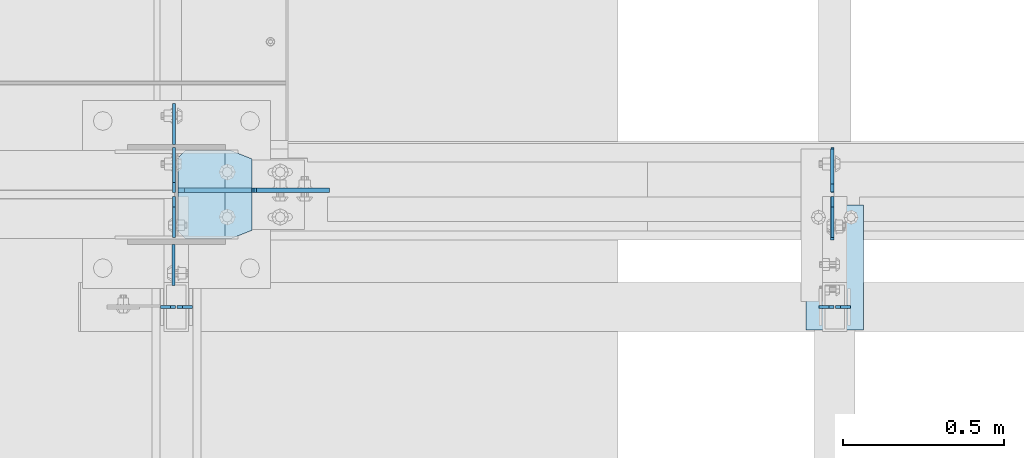
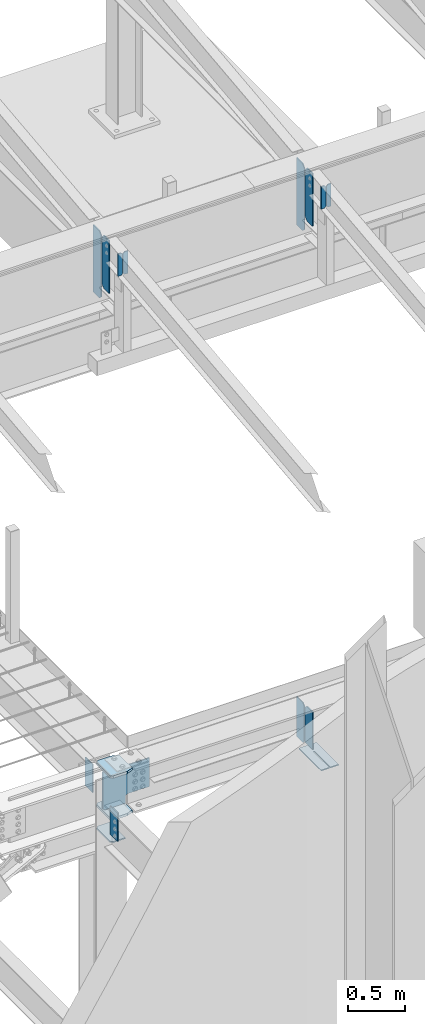
# One storey, part 988 of 1179: 17 plates, 6 elements without a shape of their own.
"""IFC2X3 building model written with IfcOpenShell, lengths in millimetres."""

from ifc_helpers import new_model, si_unit, frame, origin_with_axes, place, context, subcontext, project, spatial, faceted_brep, material, type_object, element, aggregate, save


model = new_model("IFC2X3")

# Units and contexts
model_context = context("Model", 3, precision=1e-05, world=origin_with_axes())
body_context = subcontext(model_context, "Body", "Model", "MODEL_VIEW")
ifc_project = project(units=[si_unit("LENGTHUNIT", "METRE", prefix="MILLI"), si_unit("AREAUNIT", "SQUARE_METRE"), si_unit("VOLUMEUNIT", "CUBIC_METRE"), si_unit("MASSUNIT", "GRAM", prefix="KILO"), si_unit("TIMEUNIT", "SECOND"), si_unit("PLANEANGLEUNIT", "RADIAN"), si_unit("SOLIDANGLEUNIT", "STERADIAN"), si_unit("THERMODYNAMICTEMPERATUREUNIT", "DEGREE_CELSIUS"), si_unit("LUMINOUSINTENSITYUNIT", "LUMEN")], contexts=[model_context])

# Site, building, storey
site_placement = place(None, origin_with_axes())
site = spatial("IfcSite", under=ifc_project, at=site_placement, CompositionType="ELEMENT")
building_placement = place(site_placement, origin_with_axes())
building = spatial("IfcBuilding", under=site, at=building_placement, Name="Undefined", CompositionType="ELEMENT")
storey_placement = place(building_placement, origin_with_axes())
storey = spatial("IfcBuildingStorey", under=building, at=storey_placement, Name="Undefined", CompositionType="ELEMENT", Elevation=0.0)

# Assembly, plates
assembly_1_placement = place(storey_placement, origin_with_axes())
assembly_1 = element("IfcElementAssembly", 1, at=assembly_1_placement, inside=storey, Name="BEAM", AssemblyPlace="NOTDEFINED", PredefinedType="RIGID_FRAME")
ifc_material_1 = material(Name="STEEL/A36")
plate_type_1 = type_object("IfcPlateType", PredefinedType="NOTDEFINED")
plate_1_placement = place(assembly_1_placement, frame((10317.9557500839, 5429.25933465636, 9245.8912842795), z_axis=(0.0, 0.0, 1.0), x_axis=(0.0, -1.0, 0.0)))
plate_1 = element("IfcPlate", 2, at=plate_1_placement, type_object=plate_type_1, material=ifc_material_1, Name="PLATE", context=body_context, shape_type="Brep", body=[
    faceted_brep([(1.81898940354586e-12, -4.76249999999709, 31.75), (0.0, -4.76250000000073, 531.8125), (0.0, 4.76250000000073, 531.8125), (-1.81898940354586e-12, 4.76249999998981, 31.75), (31.75, -4.76250000000073, 563.5625), (31.75, 4.76250000000073, 563.5625), (127.0, -4.76250000000073, 563.5625), (127.0, 4.76250000000073, 563.5625), (127.0, -4.76250000000073, 0.0), (127.0, 4.76250000000073, 0.0), (31.7499999988213, -4.76250000001164, 0.0), (31.7499999988249, 4.76249999998254, 0.0)], [[[0, 1, 2, 3]], [[1, 4, 5, 2]], [[4, 6, 7, 5]], [[6, 8, 9, 7]], [[8, 10, 11, 9]], [[10, 0, 3, 11]], [[5, 7, 9, 11, 3, 2]], [[10, 8, 6, 4, 1, 0]]]),
])
plate_2_placement = place(assembly_1_placement, frame((8273.25575008392, 5429.25933465636, 9245.8912842795), z_axis=(0.0, 0.0, 1.0), x_axis=(0.0, -1.0, 0.0)))
plate_2 = element("IfcPlate", 3, at=plate_2_placement, type_object=plate_type_1, material=ifc_material_1, Name="PLATE", context=body_context, shape_type="Brep", body=[
    faceted_brep([(1.81898940354586e-12, -4.76249999999709, 31.75), (0.0, -4.76250000000073, 531.8125), (0.0, 4.76250000000073, 531.8125), (-1.81898940354586e-12, 4.76249999998981, 31.75), (31.75, -4.76250000000073, 563.5625), (31.75, 4.76250000000073, 563.5625), (127.0, -4.76250000000073, 563.5625), (127.0, 4.76250000000073, 563.5625), (127.0, -4.76250000000073, 0.0), (127.0, 4.76250000000073, 0.0), (31.7499999988213, -4.76250000001164, 0.0), (31.7499999988249, 4.76249999998254, 0.0)], [[[0, 1, 2, 3]], [[1, 4, 5, 2]], [[4, 6, 7, 5]], [[6, 8, 9, 7]], [[8, 10, 11, 9]], [[10, 0, 3, 11]], [[5, 7, 9, 11, 3, 2]], [[10, 8, 6, 4, 1, 0]]]),
])

assembly_2_placement = place(storey_placement, origin_with_axes())
assembly_2 = element("IfcElementAssembly", 4, at=assembly_2_placement, inside=storey, Name="COLUMN", AssemblyPlace="NOTDEFINED", PredefinedType="RIGID_FRAME")
plate_3_placement = place(assembly_2_placement, frame((8270.87499999897, 5280.025, 3810.0), z_axis=(0.0, -1.0, 0.0), x_axis=(0.0, 0.0, -1.0)))
plate_3 = element("IfcPlate", 5, at=plate_3_placement, type_object=plate_type_1, material=ifc_material_1, Name="PLATE", context=body_context, shape_type="Brep", body=[
    faceted_brep([(0.0, -4.76249999999709, 0.0), (0.0, -4.76249999999709, 127.0), (0.0, 4.76249999999709, 127.0), (0.0, 4.76249999999709, 0.0), (304.799999999999, -4.76249999999982, 127.0), (304.799999999999, 4.76249999999982, 127.0), (304.799987792969, -4.76250000000073, 0.0), (304.799987792969, 4.76250000000073, 0.0)], [[[0, 1, 2, 3]], [[2, 1, 4, 5]], [[4, 6, 7, 5]], [[6, 0, 3, 7]], [[5, 7, 3, 2]], [[6, 4, 1, 0]]]),
])
plate_4_placement = place(assembly_2_placement, frame((8272.4625, 5591.175, 4063.99999886453), z_axis=(0.0, 1.0, 0.0), x_axis=(0.0, 0.0, -1.0)))
plate_4 = element("IfcPlate", 6, at=plate_4_placement, type_object=plate_type_1, material=ifc_material_1, Name="PLATE", context=body_context, shape_type="Brep", body=[
    faceted_brep([(0.0, -4.76249999999709, 0.0), (0.0, -4.76249999999709, 127.0), (0.0, 4.76249999999709, 127.0), (0.0, 4.76249999999709, 0.0), (304.799999999999, -4.76249999999982, 127.0), (304.799999999999, 4.76249999999982, 127.0), (304.799987792969, -4.76250000000073, 0.0), (304.799987792969, 4.76250000000073, 0.0)], [[[0, 1, 2, 3]], [[2, 1, 4, 5]], [[4, 6, 7, 5]], [[6, 0, 3, 7]], [[5, 7, 3, 2]], [[6, 4, 1, 0]]]),
])

assembly_3_placement = place(storey_placement, origin_with_axes())
assembly_3 = element("IfcElementAssembly", 7, at=assembly_3_placement, inside=storey, Name="BEAM", AssemblyPlace="NOTDEFINED", PredefinedType="RIGID_FRAME")
plate_type_2 = type_object("IfcPlateType", PredefinedType="NOTDEFINED")
plate_5_placement = place(assembly_3_placement, frame((10317.1624967425, 5576.9753907878, 3652.8375), z_axis=(0.0, 0.0, 1.0), x_axis=(0.0, -1.0, 0.0)))
plate_5 = element("IfcPlate", 8, at=plate_5_placement, type_object=plate_type_2, material=ifc_material_1, Name="PLATE", context=body_context, shape_type="Brep", body=[
    faceted_brep([(0.0, -4.76249999999709, 0.0), (-9.09494701772928e-13, -4.76250000000255, 425.450012207031), (9.09494701772928e-13, 4.76249999999891, 425.450012207031), (0.0, 4.76249999999709, 0.0), (108.743890762328, -4.76250000002983, 425.450012207031), (108.743890762331, 4.7624999999698, 425.450012207031), (134.143890380858, -4.76250000003529, 400.050012588501), (134.143890380861, 4.76249999996435, 400.050012588501), (134.143890380858, -4.76250000003529, 25.3999996185303), (134.143890380861, 4.76249999996435, 25.3999996185303), (108.743890762328, -4.76250000002983, 0.0), (108.743890762331, 4.7624999999698, 0.0)], [[[0, 1, 2, 3]], [[1, 4, 5, 2]], [[4, 6, 7, 5]], [[6, 8, 9, 7]], [[8, 10, 11, 9]], [[10, 0, 3, 11]], [[5, 7, 9, 11, 3, 2]], [[10, 8, 6, 4, 1, 0]]]),
])
plate_6_placement = place(assembly_3_placement, frame((10317.1624967425, 5294.3125001143, 3683.00001220703), z_axis=(0.0, 0.0, 1.0), x_axis=(0.0, 1.0, 0.0)))
plate_6 = element("IfcPlate", 9, at=plate_6_placement, type_object=plate_type_2, material=ifc_material_1, Name="PLATE", context=body_context, shape_type="Brep", body=[
    faceted_brep([(0.0, -4.76249999999709, 0.0), (1.81898940354586e-12, -4.76250000000437, 396.875), (0.0, 4.762500000008, 396.875), (0.0, 4.76249999999709, 0.0), (108.74389076233, -4.76249999996799, 396.875), (108.743890762327, 4.76250000003165, 396.875), (134.14389038086, -4.76249999996253, 371.47500038147), (134.143890380858, 4.76250000003711, 371.47500038147), (134.14389038086, -4.76249999996253, 0.0), (134.143890380858, 4.76250000003711, 0.0)], [[[0, 1, 2, 3]], [[1, 4, 5, 2]], [[4, 6, 7, 5]], [[6, 8, 9, 7]], [[8, 0, 3, 9]], [[5, 7, 9, 3, 2]], [[8, 6, 4, 1, 0]]]),
])
aggregate(assembly_3, [plate_5, plate_6])

# Plate
plate_type_3 = type_object("IfcPlateType", PredefinedType="NOTDEFINED")
plate_7_placement = place(assembly_1_placement, frame((10317.9557500839, 5441.95933465636, 9095.0787842795), z_axis=(0.0, 0.0, 1.0), x_axis=(0.0, 1.0, 0.0)))
plate_7 = element("IfcPlate", 10, at=plate_7_placement, type_object=plate_type_3, material=ifc_material_1, Name="PLATE", context=body_context, shape_type="Brep", body=[
    faceted_brep([(1.81898940354586e-12, -4.76249999999709, 31.75), (0.0, -4.76249999999982, 682.625), (0.0, 4.76249999999982, 682.625), (-1.81898940354586e-12, 4.76249999998981, 31.75), (31.75, -4.76249999999982, 714.375), (31.75, 4.76249999999982, 714.375), (139.7, -4.76249999999982, 714.375), (139.7, 4.76249999999982, 714.375), (139.7, -4.76249999999982, 0.0), (139.7, 4.76249999999982, 0.0), (31.7499999988213, -4.76250000001164, 0.0), (31.7499999988249, 4.76249999998254, 0.0)], [[[0, 1, 2, 3]], [[1, 4, 5, 2]], [[4, 6, 7, 5]], [[6, 8, 9, 7]], [[8, 10, 11, 9]], [[10, 0, 3, 11]], [[5, 7, 9, 11, 3, 2]], [[10, 8, 6, 4, 1, 0]]]),
])

plate_8_placement = place(assembly_1_placement, frame((8273.25575008392, 5441.95933465636, 9095.0787842795), z_axis=(0.0, 0.0, 1.0), x_axis=(0.0, 1.0, 0.0)))
plate_8 = element("IfcPlate", 11, at=plate_8_placement, type_object=plate_type_3, material=ifc_material_1, Name="PLATE", context=body_context, shape_type="Brep", body=[
    faceted_brep([(1.81898940354586e-12, -4.76249999999709, 31.75), (0.0, -4.76249999999982, 682.625), (0.0, 4.76249999999982, 682.625), (-1.81898940354586e-12, 4.76249999998981, 31.75), (31.75, -4.76249999999982, 714.375), (31.75, 4.76249999999982, 714.375), (139.7, -4.76249999999982, 714.375), (139.7, 4.76249999999982, 714.375), (139.7, -4.76249999999982, 0.0), (139.7, 4.76249999999982, 0.0), (31.7499999988213, -4.76250000001164, 0.0), (31.7499999988249, 4.76249999998254, 0.0)], [[[0, 1, 2, 3]], [[1, 4, 5, 2]], [[4, 6, 7, 5]], [[6, 8, 9, 7]], [[8, 10, 11, 9]], [[10, 0, 3, 11]], [[5, 7, 9, 11, 3, 2]], [[10, 8, 6, 4, 1, 0]]]),
])

aggregate(assembly_1, [plate_1, plate_7, plate_2, plate_8])

# Assembly, plate
assembly_4_placement = place(storey_placement, origin_with_axes())
assembly_4 = element("IfcElementAssembly", 12, at=assembly_4_placement, inside=storey, Name="BEAM", AssemblyPlace="NOTDEFINED", PredefinedType="RIGID_FRAME")
plate_type_4 = type_object("IfcPlateType", PredefinedType="NOTDEFINED")
plate_9_placement = place(assembly_4_placement, frame((10413.9999993714, 5403.05638849583, 3656.0125), z_axis=(0.0, -1.0, 0.0), x_axis=(-1.0, 0.0, 0.0)))
plate_9 = element("IfcPlate", 13, at=plate_9_placement, type_object=plate_type_4, material=ifc_material_1, Name="PLATE", context=body_context, shape_type="Brep", body=[
    faceted_brep([(84.1374995226361, -4.76249999999982, 388.143896484398), (84.1374998016308, -4.76249999999982, 108.743890683401), (84.1374998016308, 4.76249999999982, 108.743890683401), (84.1374995226361, 4.76249999999982, 388.143896484398), (93.6624994201611, -4.76249999999982, 108.743890698304), (93.6624994201611, 4.76249999999982, 108.743890698304), (93.6624981874847, -4.76249999999982, 388.143890669526), (93.6624981874847, 4.76249999999982, 388.143896484401), (0.0, -4.76249999999709, 0.0), (-1.44472687679809e-06, -4.76249999999982, 388.143896484375), (-1.44472687679809e-06, 4.76249999999982, 388.143896484375), (0.0, 4.76249999999709, 0.0), (177.800003051758, -4.76249999999982, 0.0), (177.800003051758, 4.76249999999982, 0.0), (177.799987133836, -4.76249999999982, 388.143896484426), (177.799987133836, 4.76249999999982, 388.143896484426)], [[[0, 1, 2, 3]], [[4, 5, 2, 1]], [[6, 7, 5, 4]], [[8, 9, 10, 11]], [[12, 8, 11, 13]], [[14, 12, 13, 15]], [[1, 0, 9, 8, 12, 14, 6, 4]], [[10, 9, 0, 3]], [[15, 13, 11, 10, 3, 2, 5, 7]], [[14, 15, 7, 6]]]),
])
aggregate(assembly_4, [plate_9])

# Assembly, plates
assembly_5_placement = place(storey_placement, origin_with_axes())
assembly_5 = element("IfcElementAssembly", 14, at=assembly_5_placement, inside=storey, Name="BEAM", AssemblyPlace="NOTDEFINED", PredefinedType="RIGID_FRAME")
plate_type_5 = type_object("IfcPlateType", PredefinedType="NOTDEFINED")
plate_10_placement = place(assembly_5_placement, frame((8231.1875, 5086.35, 9814.71314162917), z_axis=(0.0, 0.0, -1.0), x_axis=(1.0, 0.0, 0.0)))
plate_10 = element("IfcPlate", 15, at=plate_10_placement, type_object=plate_type_5, material=ifc_material_1, Name="PLATE", context=body_context, shape_type="Brep", body=[
    faceted_brep([(0.0, -4.76249999999709, 0.0), (0.0, -4.76249999999982, 240.171811375247), (0.0, 4.76249999999982, 240.171811375247), (0.0, 4.76249999999709, 0.0), (30.9562500000029, -4.76249999999982, 240.171811375247), (30.9562500000029, 4.76249999999982, 240.171811375247), (46.8312500000029, -4.76249999999982, 224.296811375247), (46.8312500000029, 4.76249999999982, 224.296811375247), (46.8312500000029, -4.76249999999982, 15.875), (46.8312500000029, 4.76249999999982, 15.875), (30.9562500000029, -4.76249999999982, 0.0), (30.9562500000029, 4.76249999999982, 0.0)], [[[0, 1, 2, 3]], [[1, 4, 5, 2]], [[4, 6, 7, 5]], [[6, 8, 9, 7]], [[8, 10, 11, 9]], [[10, 0, 3, 11]], [[5, 7, 9, 11, 3, 2]], [[10, 8, 6, 4, 1, 0]]]),
])
plate_11_placement = place(assembly_5_placement, frame((8282.78125, 5086.35, 9814.71314162917), z_axis=(0.0, 0.0, -1.0), x_axis=(1.0, 0.0, 0.0)))
plate_11 = element("IfcPlate", 16, at=plate_11_placement, type_object=plate_type_5, material=ifc_material_1, Name="PLATE", context=body_context, shape_type="Brep", body=[
    faceted_brep([(-1.81898940354586e-12, -4.76249999999936, 15.875), (0.0, -4.76249999999982, 224.296811375247), (0.0, 4.76249999999982, 224.296811375247), (1.81898940354586e-12, 4.76249999999936, 15.875), (15.875, -4.76249999999982, 240.171811375247), (15.875, 4.76249999999982, 240.171811375247), (46.8312500000029, -4.76249999999982, 240.171811375247), (46.8312500000029, 4.76249999999982, 240.171811375247), (46.8312500000029, -4.76249999999982, 0.0), (46.8312500000029, 4.76249999999982, 0.0), (15.8749999999891, -4.76249999999845, 0.0), (15.8749999999945, 4.76250000000027, 0.0)], [[[0, 1, 2, 3]], [[1, 4, 5, 2]], [[4, 6, 7, 5]], [[6, 8, 9, 7]], [[8, 10, 11, 9]], [[10, 0, 3, 11]], [[5, 7, 9, 11, 3, 2]], [[10, 8, 6, 4, 1, 0]]]),
])
aggregate(assembly_5, [plate_10, plate_11])

assembly_6_placement = place(storey_placement, origin_with_axes())
assembly_6 = element("IfcElementAssembly", 17, at=assembly_6_placement, inside=storey, Name="BEAM", AssemblyPlace="NOTDEFINED", PredefinedType="RIGID_FRAME")
plate_12_placement = place(assembly_6_placement, frame((10275.8875, 5086.35, 9814.71314162916), z_axis=(0.0, 0.0, -1.0), x_axis=(1.0, 0.0, 0.0)))
plate_12 = element("IfcPlate", 18, at=plate_12_placement, type_object=plate_type_5, material=ifc_material_1, Name="PLATE", context=body_context, shape_type="Brep", body=[
    faceted_brep([(0.0, -4.76249999999709, 0.0), (0.0, -4.76249999999982, 240.171811375247), (0.0, 4.76249999999982, 240.171811375247), (0.0, 4.76249999999709, 0.0), (30.9562500000029, -4.76249999999982, 240.171811375247), (30.9562500000029, 4.76249999999982, 240.171811375247), (46.8312500000029, -4.76249999999982, 224.296811375247), (46.8312500000029, 4.76249999999982, 224.296811375247), (46.8312500000029, -4.76249999999982, 15.875), (46.8312500000029, 4.76249999999982, 15.875), (30.9562500000029, -4.76249999999982, 0.0), (30.9562500000029, 4.76249999999982, 0.0)], [[[0, 1, 2, 3]], [[1, 4, 5, 2]], [[4, 6, 7, 5]], [[6, 8, 9, 7]], [[8, 10, 11, 9]], [[10, 0, 3, 11]], [[5, 7, 9, 11, 3, 2]], [[10, 8, 6, 4, 1, 0]]]),
])
plate_13_placement = place(assembly_6_placement, frame((10327.48125, 5086.35, 9814.71314162916), z_axis=(0.0, 0.0, -1.0), x_axis=(1.0, 0.0, 0.0)))
plate_13 = element("IfcPlate", 19, at=plate_13_placement, type_object=plate_type_5, material=ifc_material_1, Name="PLATE", context=body_context, shape_type="Brep", body=[
    faceted_brep([(-1.81898940354586e-12, -4.76249999999936, 15.875), (0.0, -4.76249999999982, 224.296811375247), (0.0, 4.76249999999982, 224.296811375247), (1.81898940354586e-12, 4.76249999999936, 15.875), (15.875, -4.76249999999982, 240.171811375247), (15.875, 4.76249999999982, 240.171811375247), (46.8312500000029, -4.76249999999982, 240.171811375247), (46.8312500000029, 4.76249999999982, 240.171811375247), (46.8312500000029, -4.76249999999982, 0.0), (46.8312500000029, 4.76249999999982, 0.0), (15.8749999999891, -4.76249999999845, 0.0), (15.8749999999945, 4.76250000000027, 0.0)], [[[0, 1, 2, 3]], [[1, 4, 5, 2]], [[4, 6, 7, 5]], [[6, 8, 9, 7]], [[8, 10, 11, 9]], [[10, 0, 3, 11]], [[5, 7, 9, 11, 3, 2]], [[10, 8, 6, 4, 1, 0]]]),
])
aggregate(assembly_6, [plate_12, plate_13])

# Plate
plate_type_6 = type_object("IfcPlateType", PredefinedType="NOTDEFINED")
plate_14_placement = place(assembly_2_placement, frame((8432.00625, 5299.08283793264, 3397.24997351833), z_axis=(0.0, 1.0, 0.0), x_axis=(-1.0, 0.0, 0.0)))
plate_14 = element("IfcPlate", 20, at=plate_14_placement, type_object=plate_type_6, material=ifc_material_1, Name="PLATE", context=body_context, shape_type="Brep", body=[
    faceted_brep([(0.0, -6.34999999999854, 0.0), (0.0, -6.34999999999991, 273.05), (0.0, 6.34999999999991, 273.05), (0.0, 6.34999999999854, 0.0), (123.824999618599, -6.34999999999991, 273.05), (123.824999618599, 6.34999999999991, 273.05), (146.050000000068, -6.34999999999991, 250.82499961853), (146.050000000068, 6.34999999999991, 250.82499961853), (146.050000000068, -6.34999999999991, 22.2250003814697), (146.050000000068, 6.34999999999991, 22.2250003814697), (123.824999618599, -6.34999999999991, 0.0), (123.824999618599, 6.34999999999991, 0.0)], [[[0, 1, 2, 3]], [[1, 4, 5, 2]], [[4, 6, 7, 5]], [[6, 8, 9, 7]], [[8, 10, 11, 9]], [[10, 0, 3, 11]], [[5, 7, 9, 11, 3, 2]], [[10, 8, 6, 4, 1, 0]]]),
])

ifc_material_2 = material(Name="STEEL/A572-GR.50")
plate_type_7 = type_object("IfcPlateType", PredefinedType="NOTDEFINED")
plate_15_placement = place(assembly_2_placement, frame((8514.55625, 5299.08336090282, 3641.72500000272), z_axis=(0.0, 1.0, 0.0), x_axis=(-1.0, 0.0, 0.0)))
plate_15 = element("IfcPlate", 21, at=plate_15_placement, type_object=plate_type_7, material=ifc_material_2, Name="PLATE", context=body_context, shape_type="Brep", body=[
    faceted_brep([(63.5, -12.6999999999998, 0.0), (0.0, -12.6999999999998, 25.3999996185303), (0.0, 12.6999999999998, 25.3999996185303), (63.5, 12.6999999999998, 0.0), (63.5, -12.6999999999998, 273.049013639321), (63.5, 12.6999999999998, 273.049947041699), (0.0, 12.6999999999998, 247.649013639321), (0.0, -12.6999999999998, 247.649013639321), (206.374999618531, -12.6999999999998, 273.049947041699), (206.374999618531, 12.6999999999998, 273.049947041699), (228.6, -12.6999999999998, 250.824946660229), (228.6, 12.6999999999998, 250.824946660229), (228.6, -12.6999999999998, 22.2250003814697), (228.6, 12.6999999999998, 22.2250003814697), (206.374999618531, -12.6999999999998, 0.0), (206.374999618531, 12.6999999999998, 0.0)], [[[0, 1, 2, 3]], [[4, 5, 6, 7]], [[8, 9, 5, 4]], [[8, 10, 11, 9]], [[10, 12, 13, 11]], [[12, 14, 15, 13]], [[15, 14, 0, 3]], [[6, 5, 9, 11, 13, 15, 3, 2]], [[7, 6, 2, 1]], [[14, 12, 10, 8, 4, 7, 1, 0]]]),
])

plate_16_placement = place(assembly_2_placement, frame((8514.55625, 5299.08429430519, 4089.40000000272), z_axis=(0.0, 1.0, 0.0), x_axis=(-1.0, 0.0, 0.0)))
plate_16 = element("IfcPlate", 22, at=plate_16_placement, type_object=plate_type_7, material=ifc_material_2, Name="PLATE", context=body_context, shape_type="Brep", body=[
    faceted_brep([(63.5, -12.6999999999998, 0.0), (0.0, -12.6999999999998, 25.3999996185303), (0.0, 12.6999999999998, 25.3999996185303), (63.5, 12.6999999999998, 0.0), (63.5, -12.6999999999998, 273.049013639321), (63.5, 12.6999999999998, 273.049947041699), (0.0, 12.6999999999998, 247.649013639321), (0.0, -12.6999999999998, 247.649013639321), (206.374999618531, -12.6999999999998, 273.049947041699), (206.374999618531, 12.6999999999998, 273.049947041699), (228.6, -12.6999999999998, 250.824946660229), (228.6, 12.6999999999998, 250.824946660229), (228.6, -12.6999999999998, 22.2250003814697), (228.6, 12.6999999999998, 22.2250003814697), (206.374999618531, -12.6999999999998, 0.0), (206.374999618531, 12.6999999999998, 0.0)], [[[0, 1, 2, 3]], [[4, 5, 6, 7]], [[8, 9, 5, 4]], [[8, 10, 11, 9]], [[10, 12, 13, 11]], [[12, 14, 15, 13]], [[15, 14, 0, 3]], [[6, 5, 9, 11, 13, 15, 3, 2]], [[7, 6, 2, 1]], [[14, 12, 10, 8, 4, 7, 1, 0]]]),
])

plate_type_8 = type_object("IfcPlateType", PredefinedType="NOTDEFINED")
plate_17_placement = place(assembly_2_placement, frame((8285.95625, 5449.09375009537, 3673.47500339458), z_axis=(0.707106781186573, 0.0, 0.707106781186522), x_axis=(0.707106781186522, 0.0, -0.707106781186573)))
plate_17 = element("IfcPlate", 23, at=plate_17_placement, type_object=plate_type_8, material=ifc_material_2, Name="PLATE", context=body_context, shape_type="Brep", body=[
    faceted_brep([(0.0, -6.34999999999854, 0.0), (-271.652749686205, -6.35000000000036, 271.652745638487), (-271.652749686205, 6.35000000000036, 271.652745638487), (0.0, 6.34999999999854, 0.0), (-271.652749686187, -6.35000000000036, 298.59351380097), (-271.652749686187, 6.35000000000036, 298.59351380097), (-124.039789129293, -6.35000000000036, 446.206471618534), (-124.039789129293, 6.35000000000036, 446.206471618534), (-115.799436151971, -6.35000000000036, 440.700443878972), (-115.799436151971, 6.35000000000036, 440.700443878972), (-106.079277101483, -6.35000000000036, 438.766984106212), (-106.079277101483, 6.35000000000036, 438.766984106212), (-96.3591180798026, -6.35000000000036, 440.700444023802), (-96.3591180798026, 6.35000000000036, 440.700444023802), (-88.1187651845203, -6.35000000000036, 446.206471886146), (-88.1187651845203, 6.35000000000036, 446.206471886146), (64.5455920540821, -6.35000000000036, 598.870831399401), (64.5455920540821, 6.35000000000036, 598.870831399401), (280.071740565453, -6.35000000000036, 383.344686099445), (280.071740565453, 6.35000000000036, 383.344686099445), (127.407383326885, -6.35000000000036, 230.680326586225), (127.407383326885, 6.35000000000036, 230.680326586225), (121.901355587314, -6.35000000000036, 222.439973608891), (121.901355587314, 6.35000000000036, 222.439973608891), (119.967895814552, -6.35000000000036, 212.719814558384), (119.967895814552, 6.35000000000036, 212.719814558384), (121.901355732145, -6.35000000000036, 202.999655536687), (121.901355732145, 6.35000000000036, 202.999655536687), (127.407383594497, -6.35000000000036, 194.759302641392), (127.407383594497, 6.35000000000036, 194.759302641392), (174.553728352508, -6.34999999999854, 147.612959989299), (174.553728352508, 6.34999999999854, 147.612959989299), (26.9407683631471, -6.34999999999854, -6.91215973347425e-11), (26.9407683631471, 6.34999999999854, -6.91215973347425e-11)], [[[0, 1, 2, 3]], [[1, 4, 5, 2]], [[4, 6, 7, 5]], [[6, 8, 9, 7]], [[8, 10, 11, 9]], [[10, 12, 13, 11]], [[12, 14, 15, 13]], [[14, 16, 17, 15]], [[16, 18, 19, 17]], [[18, 20, 21, 19]], [[20, 22, 23, 21]], [[22, 24, 25, 23]], [[24, 26, 27, 25]], [[26, 28, 29, 27]], [[28, 30, 31, 29]], [[30, 32, 33, 31]], [[32, 0, 3, 33]], [[5, 7, 9, 11, 13, 15, 17, 19, 21, 23, 25, 27, 29, 31, 33, 3, 2]], [[32, 30, 28, 26, 24, 22, 20, 18, 16, 14, 12, 10, 8, 6, 4, 1, 0]]]),
])

aggregate(assembly_2, [plate_14, plate_15, plate_16, plate_17, plate_3, plate_4])

save(model, "model.ifc")
